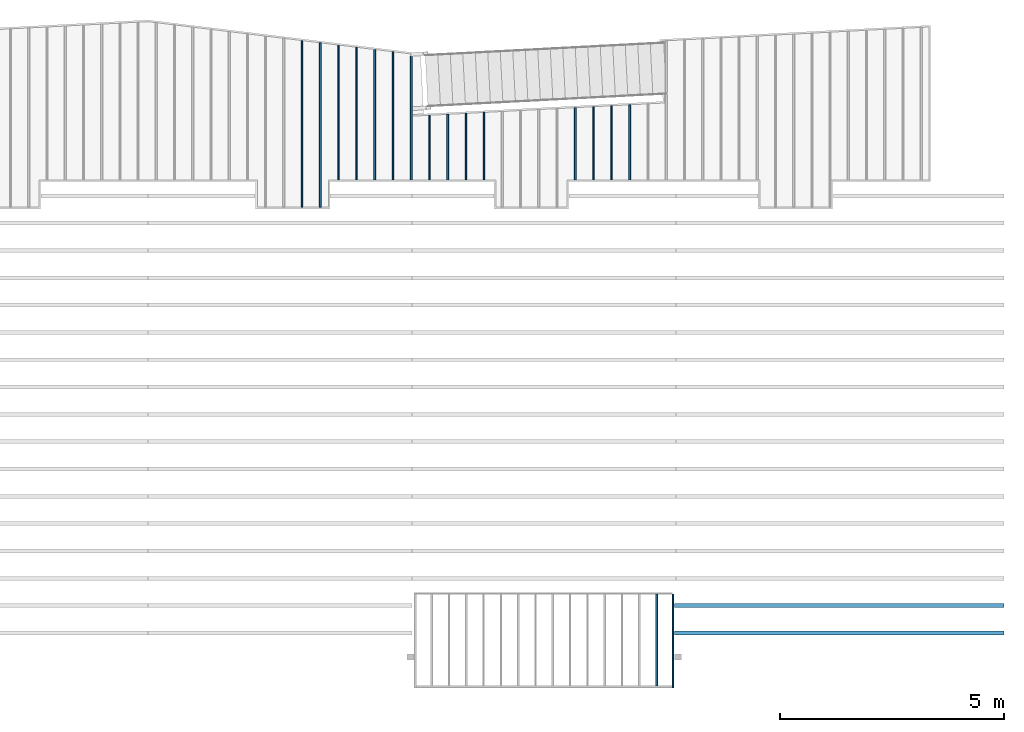
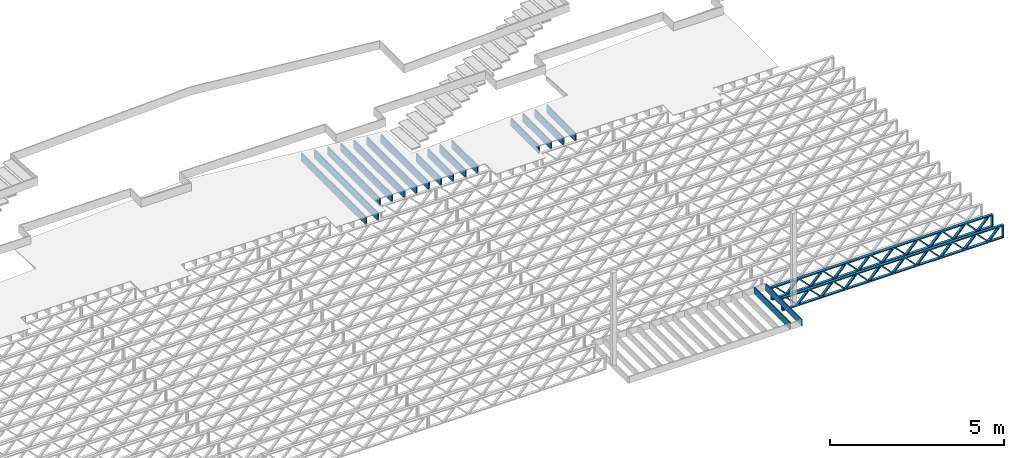
# One storey, part 10 of 23: 19 beams, 3 elements without a shape of their own.
"""IFC4 building model written with IfcOpenShell, lengths in feet."""

from ifc_helpers import new_model, entity, si_unit, converted_unit, derived_unit, direction, frame, frame_2d, origin, origin_2d_with_axis, place, context, subcontext, project, spatial, rectangle, extrude, source, transform, mapped, material, material_profile, profile_set, profile_usage, type_object, type_shapes, element, aggregate, save


model = new_model("IFC4")

# Units and contexts
model_context = context("Model", 3, precision=0.0001, world=origin(), true_north=direction((6.12303176911189e-17, 1.0)))
body_context = subcontext(model_context, "Body", "Model", "MODEL_VIEW")
ifc_project = project(units=[converted_unit("LENGTHUNIT", "FOOT", entity("IfcRatioMeasure", 0.3048), si_unit("LENGTHUNIT", "METRE"), dimensions=[1, 0, 0, 0, 0, 0, 0]), converted_unit("AREAUNIT", "SQUARE FOOT", entity("IfcRatioMeasure", 0.09290304), si_unit("AREAUNIT", "SQUARE_METRE"), dimensions=[2, 0, 0, 0, 0, 0, 0]), converted_unit("VOLUMEUNIT", "CUBIC FOOT", entity("IfcRatioMeasure", 0.028316846592), si_unit("VOLUMEUNIT", "CUBIC_METRE"), dimensions=[3, 0, 0, 0, 0, 0, 0]), converted_unit("PLANEANGLEUNIT", "DEGREE", entity("IfcRatioMeasure", 0.0174532925199433), si_unit("PLANEANGLEUNIT", "RADIAN"), dimensions=[0, 0, 0, 0, 0, 0, 0]), si_unit("MASSUNIT", "GRAM", prefix="KILO"), derived_unit("MASSDENSITYUNIT", [(si_unit("MASSUNIT", "GRAM", prefix="KILO"), 1), (si_unit("LENGTHUNIT", "METRE"), -3)]), derived_unit("MOMENTOFINERTIAUNIT", [(si_unit("LENGTHUNIT", "METRE"), 4)]), si_unit("TIMEUNIT", "SECOND"), si_unit("FREQUENCYUNIT", "HERTZ"), si_unit("THERMODYNAMICTEMPERATUREUNIT", "DEGREE_CELSIUS"), derived_unit("THERMALTRANSMITTANCEUNIT", [(si_unit("MASSUNIT", "GRAM", prefix="KILO"), 1), (si_unit("THERMODYNAMICTEMPERATUREUNIT", "KELVIN"), -1), (si_unit("TIMEUNIT", "SECOND"), -3)]), derived_unit("VOLUMETRICFLOWRATEUNIT", [(si_unit("LENGTHUNIT", "METRE"), 3), (si_unit("TIMEUNIT", "SECOND"), -1)]), si_unit("ELECTRICCURRENTUNIT", "AMPERE"), si_unit("ELECTRICVOLTAGEUNIT", "VOLT"), si_unit("POWERUNIT", "WATT"), si_unit("FORCEUNIT", "NEWTON"), si_unit("ILLUMINANCEUNIT", "LUX"), si_unit("LUMINOUSFLUXUNIT", "LUMEN"), si_unit("LUMINOUSINTENSITYUNIT", "CANDELA"), derived_unit("USERDEFINED", [(si_unit("MASSUNIT", "GRAM", prefix="KILO"), -1), (si_unit("LENGTHUNIT", "METRE"), -2), (si_unit("TIMEUNIT", "SECOND"), 3), (si_unit("LUMINOUSFLUXUNIT", "LUMEN"), 1)]), derived_unit("LINEARVELOCITYUNIT", [(si_unit("LENGTHUNIT", "METRE"), 1), (si_unit("TIMEUNIT", "SECOND"), -1)]), si_unit("PRESSUREUNIT", "PASCAL"), derived_unit("USERDEFINED", [(si_unit("LENGTHUNIT", "METRE"), -2), (si_unit("MASSUNIT", "GRAM", prefix="KILO"), 1), (si_unit("TIMEUNIT", "SECOND"), -2)]), derived_unit("LINEARFORCEUNIT", [(si_unit("MASSUNIT", "GRAM", prefix="KILO"), 1), (si_unit("LENGTHUNIT", "METRE"), 1), (si_unit("TIMEUNIT", "SECOND"), -2), (si_unit("LENGTHUNIT", "METRE"), -1)]), derived_unit("PLANARFORCEUNIT", [(si_unit("MASSUNIT", "GRAM", prefix="KILO"), 1), (si_unit("LENGTHUNIT", "METRE"), 1), (si_unit("TIMEUNIT", "SECOND"), -2), (si_unit("LENGTHUNIT", "METRE"), -2)])], contexts=[model_context])

# Site, building, storey
site_placement = place(None, origin())
site = spatial("IfcSite", under=ifc_project, at=site_placement, CompositionType="ELEMENT")
building_placement = place(site_placement, origin())
building = spatial("IfcBuilding", under=site, at=building_placement, CompositionType="ELEMENT")
storey_placement = place(building_placement, frame((0.0, 0.0, 10.8020833333333)))
storey = spatial("IfcBuildingStorey", under=building, at=storey_placement, Name="2ND FLOOR", CompositionType="ELEMENT", Elevation=10.8020833333333)

# Assembly, beam
assembly_1_placement = place(storey_placement, origin())
assembly_1 = element("IfcElementAssembly", 1, at=assembly_1_placement, inside=storey, Name="Structural Beam System:Structural Framing System", ObjectType="Structural Beam System:Structural Framing System", AssemblyPlace="NOTDEFINED", PredefinedType="BEAM_GRID")
ifc_material_1 = material(Category="Materials")
ifc_material_profile_1 = material_profile(ifc_material_1, rectangle(XDim=0.770833333333333, YDim=0.124999999999994, at=frame_2d((-5.55111512312578e-17, 0.0), x_axis=(1.0, 0.0))))
ifc_profile_set_1 = profile_set([ifc_material_profile_1])
ifc_profile_usage_1 = profile_usage(ifc_profile_set_1, cardinal=8)
beam_type_1 = type_object("IfcBeamType", PredefinedType="BEAM", material=ifc_profile_set_1)
shared_shape_1 = source(origin(), body_context, "Body", "SweptSolid", [
    extrude(rectangle(XDim=0.770833333333333, YDim=0.124999999999994, at=frame_2d((-5.55111512312578e-17, 0.0), x_axis=(1.0, 0.0))), frame((-3.35416666666737, 0.0, 0.0), z_axis=(1.0, 0.0, 0.0), x_axis=(0.0, 0.0, -1.0)), (0.0, 0.0, 1.0), 6.70833333333462),
])
type_shapes(beam_type_1, [shared_shape_1])
beam_1_placement = place(assembly_1_placement, frame((-165.83512302263, 925.341101549316, -0.645833333333471), z_axis=(0.0, 0.0, 1.0), x_axis=(0.0, 1.0, 0.0)))
beam_1 = element("IfcBeam", 2, at=beam_1_placement, type_object=beam_type_1, material=ifc_profile_usage_1, PredefinedType="BEAM", context=body_context, shape_type="MappedRepresentation", body=[
    mapped(shared_shape_1, transform((0.0, 0.0, 0.0), scale=1.0)),
])
aggregate(assembly_1, [beam_1])

# Assembly, beams
assembly_2_placement = place(storey_placement, origin())
assembly_2 = element("IfcElementAssembly", 3, at=assembly_2_placement, inside=storey, Name="Structural Beam System:Structural Framing System", ObjectType="Structural Beam System:Structural Framing System", AssemblyPlace="NOTDEFINED", PredefinedType="BEAM_GRID")
ifc_material_2 = material(Name="WOOD TRUSS", Category="Materials")
ifc_material_profile_2 = material_profile(ifc_material_2, rectangle(XDim=1.73473973950632, YDim=0.125, at=frame_2d((-1.11022302462516e-16, 8.32667268468867e-17), x_axis=(1.0, 0.0))))
ifc_material_profile_3 = material_profile(ifc_material_2, rectangle(XDim=1.73473973950633, YDim=0.125, at=frame_2d((-1.11022302462516e-16, 8.32667268468867e-17), x_axis=(1.0, 0.0))))
ifc_material_profile_4 = material_profile(ifc_material_2, rectangle(XDim=1.73473973950632, YDim=0.125, at=frame_2d((-5.55111512312578e-17, 1.38777878078145e-16), x_axis=(1.0, 0.0))))
ifc_material_profile_5 = material_profile(ifc_material_2, rectangle(XDim=1.73473973950633, YDim=0.125, at=frame_2d((-1.11022302462516e-16, 8.32667268468867e-17), x_axis=(1.0, 0.0))))
ifc_material_profile_6 = material_profile(ifc_material_2, rectangle(XDim=1.73473973950632, YDim=0.125, at=frame_2d((-1.11022302462516e-16, 8.32667268468867e-17), x_axis=(1.0, 0.0))))
ifc_material_profile_7 = material_profile(ifc_material_2, rectangle(XDim=1.73473973950633, YDim=0.125, at=frame_2d((-2.77555756156289e-16, 3.05311331771918e-16), x_axis=(1.0, 0.0))))
ifc_material_profile_8 = material_profile(ifc_material_2, rectangle(XDim=1.73473973950632, YDim=0.124999999999999, at=frame_2d((-3.88578058618805e-16, -2.4980018054066e-16), x_axis=(1.0, 0.0))))
ifc_material_profile_9 = material_profile(ifc_material_2, rectangle(XDim=1.73473973950633, YDim=0.125, at=frame_2d((2.77555756156289e-16, -3.05311331771918e-16), x_axis=(1.0, 0.0))))
ifc_material_profile_10 = material_profile(ifc_material_2, rectangle(XDim=1.73473973950632, YDim=0.124999999999999, at=frame_2d((-1.11022302462516e-16, 8.32667268468867e-17), x_axis=(1.0, 0.0))))
ifc_material_profile_11 = material_profile(ifc_material_2, rectangle(XDim=1.73473973950633, YDim=0.125, at=origin_2d_with_axis()))
ifc_material_profile_12 = material_profile(ifc_material_2, rectangle(XDim=0.124999999999982, YDim=0.291666666666668, at=origin_2d_with_axis()))
ifc_material_profile_13 = material_profile(ifc_material_2, rectangle(XDim=0.124999999999932, YDim=0.291666666666664, at=origin_2d_with_axis()))
ifc_material_profile_14 = material_profile(ifc_material_2, rectangle(XDim=1.25000000000002, YDim=0.29166666666667, at=origin_2d_with_axis()))
ifc_material_profile_15 = material_profile(ifc_material_2, rectangle(XDim=1.25000000000004, YDim=0.291666666666667, at=origin_2d_with_axis()))
ifc_profile_set_2 = profile_set([ifc_material_profile_2, ifc_material_profile_3, ifc_material_profile_4, ifc_material_profile_5, ifc_material_profile_6, ifc_material_profile_7, ifc_material_profile_8, ifc_material_profile_9, ifc_material_profile_10, ifc_material_profile_11, ifc_material_profile_12, ifc_material_profile_13, ifc_material_profile_14, ifc_material_profile_15])
ifc_profile_usage_2 = profile_usage(ifc_profile_set_2, cardinal=8)
beam_type_2 = type_object("IfcBeamType", PredefinedType="BEAM", material=ifc_profile_set_2)
shared_shape_2 = source(origin(), body_context, "Body", "SweptSolid", [
    extrude(rectangle(XDim=1.73473973950632, YDim=0.124999999999999, at=frame_2d((5.55111512312578e-16, 7.21644966006352e-16), x_axis=(1.0, 0.0))), frame((8.42202085580899, -0.145833333333334, 0.0), z_axis=(0.0, 1.0, 0.0), x_axis=(0.693383046997606, 0.0, 0.720569184836762)), (0.0, 0.0, 1.0), 0.291666666666667),
    extrude(rectangle(XDim=1.73473973950633, YDim=0.125, at=origin_2d_with_axis()), frame((7.17173498213572, -0.145833333333334, 0.0), z_axis=(0.0, 1.0, 0.0), x_axis=(0.69338304699761, 0.0, -0.720569184836758)), (0.0, 0.0, 1.0), 0.291666666666666),
    extrude(rectangle(XDim=1.73473973950632, YDim=0.124999999999999, at=frame_2d((-1.11022302462516e-16, 8.32667268468867e-17), x_axis=(1.0, 0.0))), frame((5.82306154948498, -0.145833333333334, 0.0), z_axis=(0.0, 1.0, 0.0), x_axis=(0.693383046997606, 0.0, 0.720569184836762)), (0.0, 0.0, 1.0), 0.291666666666667),
    extrude(rectangle(XDim=1.73473973950633, YDim=0.125, at=origin_2d_with_axis()), frame((4.57277567581171, -0.145833333333334, 0.0), z_axis=(0.0, 1.0, 0.0), x_axis=(0.69338304699761, 0.0, -0.720569184836758)), (0.0, 0.0, 1.0), 0.291666666666666),
    extrude(rectangle(XDim=1.73473973950632, YDim=0.125, at=frame_2d((2.22044604925031e-16, 3.88578058618805e-16), x_axis=(1.0, 0.0))), frame((3.22410224316097, -0.145833333333334, 0.0), z_axis=(0.0, 1.0, 0.0), x_axis=(0.693383046997606, 0.0, 0.720569184836762)), (0.0, 0.0, 1.0), 0.291666666666667),
    extrude(rectangle(XDim=1.73473973950633, YDim=0.125, at=frame_2d((-1.11022302462516e-16, 8.32667268468867e-17), x_axis=(1.0, 0.0))), frame((1.9738163694877, -0.145833333333334, 0.0), z_axis=(0.0, 1.0, 0.0), x_axis=(0.69338304699761, 0.0, -0.720569184836758)), (0.0, 0.0, 1.0), 0.291666666666667),
    extrude(rectangle(XDim=1.73473973950632, YDim=0.125, at=frame_2d((-5.55111512312578e-17, 1.38777878078145e-16), x_axis=(1.0, 0.0))), frame((0.625142936836964, -0.145833333333334, 0.0), z_axis=(0.0, 1.0, 0.0), x_axis=(0.693383046997606, 0.0, 0.720569184836762)), (0.0, 0.0, 1.0), 0.291666666666667),
    extrude(rectangle(XDim=1.73473973950633, YDim=0.125, at=frame_2d((-1.11022302462516e-16, 8.32667268468867e-17), x_axis=(1.0, 0.0))), frame((-0.625142936836306, -0.145833333333334, 0.0), z_axis=(0.0, 1.0, 0.0), x_axis=(0.69338304699761, 0.0, -0.720569184836758)), (0.0, 0.0, 1.0), 0.291666666666667),
    extrude(rectangle(XDim=1.73473973950632, YDim=0.125, at=frame_2d((-1.11022302462516e-16, 8.32667268468867e-17), x_axis=(1.0, 0.0))), frame((-1.97381636948704, -0.145833333333334, 0.0), z_axis=(0.0, 1.0, 0.0), x_axis=(0.693383046997606, 0.0, 0.720569184836762)), (0.0, 0.0, 1.0), 0.291666666666667),
    extrude(rectangle(XDim=1.73473973950633, YDim=0.125, at=origin_2d_with_axis()), frame((-3.22410224316031, -0.145833333333334, 0.0), z_axis=(0.0, 1.0, 0.0), x_axis=(0.69338304699761, 0.0, -0.720569184836758)), (0.0, 0.0, 1.0), 0.291666666666667),
    extrude(rectangle(XDim=1.73473973950632, YDim=0.124999999999999, at=frame_2d((-1.11022302462516e-16, 8.32667268468867e-17), x_axis=(1.0, 0.0))), frame((-4.57277567581105, -0.145833333333334, 0.0), z_axis=(0.0, 1.0, 0.0), x_axis=(0.693383046997606, 0.0, 0.720569184836762)), (0.0, 0.0, 1.0), 0.291666666666667),
    extrude(rectangle(XDim=1.73473973950633, YDim=0.125, at=origin_2d_with_axis()), frame((-5.82306154948432, -0.145833333333334, 0.0), z_axis=(0.0, 1.0, 0.0), x_axis=(0.69338304699761, 0.0, -0.720569184836758)), (0.0, 0.0, 1.0), 0.291666666666666),
    extrude(rectangle(XDim=1.73473973950632, YDim=0.124999999999999, at=frame_2d((-1.11022302462516e-16, 8.32667268468867e-17), x_axis=(1.0, 0.0))), frame((-7.17173498213506, -0.145833333333334, 0.0), z_axis=(0.0, 1.0, 0.0), x_axis=(0.693383046997606, 0.0, 0.720569184836762)), (0.0, 0.0, 1.0), 0.291666666666667),
    extrude(rectangle(XDim=1.73473973950633, YDim=0.125, at=frame_2d((-2.77555756156289e-16, 3.05311331771918e-16), x_axis=(1.0, 0.0))), frame((-8.42202085580833, -0.145833333333334, 0.0), z_axis=(0.0, 1.0, 0.0), x_axis=(0.69338304699761, 0.0, -0.720569184836758)), (0.0, 0.0, 1.0), 0.291666666666666),
    extrude(rectangle(XDim=1.73473973950632, YDim=0.125, at=frame_2d((-7.21644966006352e-16, -5.55111512312578e-16), x_axis=(1.0, 0.0))), frame((11.020980162133, -0.145833333333334, 0.0), z_axis=(0.0, 1.0, 0.0), x_axis=(0.693383046997606, 0.0, 0.720569184836762)), (0.0, 0.0, 1.0), 0.291666666666667),
    extrude(rectangle(XDim=1.73473973950633, YDim=0.125, at=origin_2d_with_axis()), frame((9.77069428845972, -0.145833333333334, 0.0), z_axis=(0.0, 1.0, 0.0), x_axis=(0.69338304699761, 0.0, -0.720569184836758)), (0.0, 0.0, 1.0), 0.291666666666666),
    extrude(rectangle(XDim=1.73473973950632, YDim=0.125, at=frame_2d((-5.55111512312578e-17, 8.32667268468867e-17), x_axis=(1.0, 0.0))), frame((-9.77069428845906, -0.145833333333334, 0.0), z_axis=(0.0, 1.0, 0.0), x_axis=(0.693383046997606, 0.0, 0.720569184836762)), (0.0, 0.0, 1.0), 0.291666666666667),
    extrude(rectangle(XDim=1.73473973950633, YDim=0.125, at=origin_2d_with_axis()), frame((-11.0209801621323, -0.145833333333334, 0.0), z_axis=(0.0, 1.0, 0.0), x_axis=(0.69338304699761, 0.0, -0.720569184836758)), (0.0, 0.0, 1.0), 0.291666666666666),
    extrude(rectangle(XDim=0.124999999999982, YDim=0.291666666666668, at=origin_2d_with_axis()), frame((-12.0625038919626, 0.0, 0.687500000000054), z_axis=(1.0, 0.0, 0.0), x_axis=(0.0, 0.0, -1.0)), (0.0, 0.0, 1.0), 24.1250077839252),
    extrude(rectangle(XDim=0.124999999999932, YDim=0.291666666666664, at=origin_2d_with_axis()), frame((-12.0625038919624, 0.0, -0.687499999999984), z_axis=(1.0, 0.0, 0.0), x_axis=(0.0, 0.0, -1.0)), (0.0, 0.0, 1.0), 24.125007783925),
    extrude(rectangle(XDim=1.25000000000002, YDim=0.29166666666667, at=origin_2d_with_axis()), frame((11.9375038919626, 0.0, 0.0), z_axis=(1.0, 0.0, 0.0), x_axis=(0.0, 0.0, -1.0)), (0.0, 0.0, 1.0), 0.12500000000002),
    extrude(rectangle(XDim=1.25000000000004, YDim=0.291666666666667, at=origin_2d_with_axis()), frame((-12.0625038919626, 0.0, 0.0), z_axis=(1.0, 0.0, 0.0), x_axis=(0.0, 0.0, -1.0)), (0.0, 0.0, 1.0), 0.125000000000023),
])
type_shapes(beam_type_2, [shared_shape_2])
beam_2_placement = place(assembly_2_placement, frame((-152.467323260299, 927.861934882651, -0.947916666657859), z_axis=(0.0, 0.0, 1.0), x_axis=(-1.0, 0.0, 0.0)))
beam_2 = element("IfcBeam", 4, at=beam_2_placement, type_object=beam_type_2, material=ifc_profile_usage_2, PredefinedType="BEAM", context=body_context, shape_type="MappedRepresentation", body=[
    mapped(shared_shape_2, transform((0.0, 0.0, 0.0), scale=1.0)),
])
ifc_profile_usage_3 = profile_usage(ifc_profile_set_2, cardinal=8)
beam_3_placement = place(assembly_2_placement, frame((-152.467323260299, 925.861934882651, -0.947916666657859), z_axis=(0.0, 0.0, 1.0), x_axis=(-1.0, 0.0, 0.0)))
beam_3 = element("IfcBeam", 5, at=beam_3_placement, type_object=beam_type_2, material=ifc_profile_usage_3, PredefinedType="BEAM", context=body_context, shape_type="MappedRepresentation", body=[
    mapped(shared_shape_2, transform((0.0, 0.0, 0.0), scale=1.0)),
])
aggregate(assembly_2, [beam_2, beam_3])

assembly_3_placement = place(storey_placement, origin())
assembly_3 = element("IfcElementAssembly", 6, at=assembly_3_placement, inside=storey, Name="Structural Beam System:Structural Framing System", ObjectType="Structural Beam System:Structural Framing System", AssemblyPlace="NOTDEFINED", PredefinedType="BEAM_GRID")
ifc_material_profile_16 = material_profile(ifc_material_1, rectangle(XDim=0.9375, YDim=0.125000000000011, at=origin_2d_with_axis()))
ifc_profile_set_3 = profile_set([ifc_material_profile_16])
ifc_profile_usage_4 = profile_usage(ifc_profile_set_3, cardinal=8)
beam_type_3 = type_object("IfcBeamType", PredefinedType="BEAM", material=ifc_profile_set_3)
shared_shape_3 = source(origin(), body_context, "Body", "SweptSolid", [
    extrude(rectangle(XDim=0.9375, YDim=0.125000000000011, at=origin_2d_with_axis()), frame((-6.09867256371109, 0.0, 0.0), z_axis=(1.0, 0.0, 0.0), x_axis=(0.0, 0.0, -1.0)), (0.0, 0.0, 1.0), 12.1973451274222),
])
type_shapes(beam_type_3, [shared_shape_3])
beam_4_placement = place(assembly_3_placement, frame((-191.800660485462, 963.127274113029, -0.729166666666744), z_axis=(0.0, 0.0, 1.0), x_axis=(0.0, 1.0, 0.0)))
beam_4 = element("IfcBeam", 7, at=beam_4_placement, type_object=beam_type_3, material=ifc_profile_usage_4, PredefinedType="BEAM", context=body_context, shape_type="MappedRepresentation", body=[
    mapped(shared_shape_3, transform((0.0, 0.0, 0.0), scale=1.0)),
])
ifc_profile_usage_5 = profile_usage(ifc_profile_set_3, cardinal=8)
beam_type_4 = type_object("IfcBeamType", PredefinedType="BEAM", material=ifc_profile_set_3)
shared_shape_4 = source(origin(), body_context, "Body", "SweptSolid", [
    extrude(rectangle(XDim=0.9375, YDim=0.125000000000011, at=origin_2d_with_axis()), frame((-6.01681618977585, 0.0, 0.0), z_axis=(1.0, 0.0, 0.0), x_axis=(0.0, 0.0, -1.0)), (0.0, 0.0, 1.0), 12.0336323795517),
])
type_shapes(beam_type_4, [shared_shape_4])
beam_5_placement = place(assembly_3_placement, frame((-190.467327152129, 963.045417739093, -0.729166666666744), z_axis=(0.0, 0.0, 1.0), x_axis=(0.0, 1.0, 0.0)))
beam_5 = element("IfcBeam", 8, at=beam_5_placement, type_object=beam_type_4, material=ifc_profile_usage_5, PredefinedType="BEAM", context=body_context, shape_type="MappedRepresentation", body=[
    mapped(shared_shape_4, transform((0.0, 0.0, 0.0), scale=1.0)),
])
ifc_profile_usage_6 = profile_usage(ifc_profile_set_3, cardinal=8)
beam_type_5 = type_object("IfcBeamType", PredefinedType="BEAM", material=ifc_profile_set_3)
shared_shape_5 = source(origin(), body_context, "Body", "SweptSolid", [
    extrude(rectangle(XDim=0.9375, YDim=0.125000000000011, at=origin_2d_with_axis()), frame((-4.93495819808015, 0.0, 0.0), z_axis=(1.0, 0.0, 0.0), x_axis=(0.0, 0.0, -1.0)), (0.0, 0.0, 1.0), 9.86991639616031),
])
type_shapes(beam_type_5, [shared_shape_5])
beam_6_placement = place(assembly_3_placement, frame((-189.133993818795, 963.963562982918, -0.729166666666744), z_axis=(0.0, 0.0, 1.0), x_axis=(0.0, 1.0, 0.0)))
beam_6 = element("IfcBeam", 9, at=beam_6_placement, type_object=beam_type_5, material=ifc_profile_usage_6, PredefinedType="BEAM", context=body_context, shape_type="MappedRepresentation", body=[
    mapped(shared_shape_5, transform((0.0, 0.0, 0.0), scale=1.0)),
])
ifc_profile_usage_7 = profile_usage(ifc_profile_set_3, cardinal=8)
beam_type_6 = type_object("IfcBeamType", PredefinedType="BEAM", material=ifc_profile_set_3)
shared_shape_6 = source(origin(), body_context, "Body", "SweptSolid", [
    extrude(rectangle(XDim=0.9375, YDim=0.125000000000011, at=origin_2d_with_axis()), frame((-4.85310198264193, 0.0, 0.0), z_axis=(1.0, 0.0, 0.0), x_axis=(0.0, 0.0, -1.0)), (0.0, 0.0, 1.0), 9.70620396528386),
])
type_shapes(beam_type_6, [shared_shape_6])
beam_7_placement = place(assembly_3_placement, frame((-187.800660485462, 963.881706450486, -0.729166666666744), z_axis=(0.0, 0.0, 1.0), x_axis=(0.0, 1.0, 0.0)))
beam_7 = element("IfcBeam", 10, at=beam_7_placement, type_object=beam_type_6, material=ifc_profile_usage_7, PredefinedType="BEAM", context=body_context, shape_type="MappedRepresentation", body=[
    mapped(shared_shape_6, transform((0.0, 0.0, 0.0), scale=1.0)),
])
ifc_profile_usage_8 = profile_usage(ifc_profile_set_3, cardinal=8)
beam_type_7 = type_object("IfcBeamType", PredefinedType="BEAM", material=ifc_profile_set_3)
shared_shape_7 = source(origin(), body_context, "Body", "SweptSolid", [
    extrude(rectangle(XDim=0.9375, YDim=0.125000000000011, at=origin_2d_with_axis()), frame((-4.77124576720365, 0.0, 0.0), z_axis=(1.0, 0.0, 0.0), x_axis=(0.0, 0.0, -1.0)), (0.0, 0.0, 1.0), 9.5424915344073),
])
type_shapes(beam_type_7, [shared_shape_7])
beam_8_placement = place(assembly_3_placement, frame((-186.467327152129, 963.799849918054, -0.729166666666744), z_axis=(0.0, 0.0, 1.0), x_axis=(0.0, 1.0, 0.0)))
beam_8 = element("IfcBeam", 11, at=beam_8_placement, type_object=beam_type_7, material=ifc_profile_usage_8, PredefinedType="BEAM", context=body_context, shape_type="MappedRepresentation", body=[
    mapped(shared_shape_7, transform((0.0, 0.0, 0.0), scale=1.0)),
])
ifc_profile_usage_9 = profile_usage(ifc_profile_set_3, cardinal=8)
beam_type_8 = type_object("IfcBeamType", PredefinedType="BEAM", material=ifc_profile_set_3)
shared_shape_8 = source(origin(), body_context, "Body", "SweptSolid", [
    extrude(rectangle(XDim=0.9375, YDim=0.125000000000011, at=origin_2d_with_axis()), frame((-4.68938955176543, 0.0, 0.0), z_axis=(1.0, 0.0, 0.0), x_axis=(0.0, 0.0, -1.0)), (0.0, 0.0, 1.0), 9.37877910353086),
])
type_shapes(beam_type_8, [shared_shape_8])
beam_9_placement = place(assembly_3_placement, frame((-185.133993818795, 963.717993385622, -0.729166666666744), z_axis=(0.0, 0.0, 1.0), x_axis=(0.0, 1.0, 0.0)))
beam_9 = element("IfcBeam", 12, at=beam_9_placement, type_object=beam_type_8, material=ifc_profile_usage_9, PredefinedType="BEAM", context=body_context, shape_type="MappedRepresentation", body=[
    mapped(shared_shape_8, transform((0.0, 0.0, 0.0), scale=1.0)),
])
ifc_profile_usage_10 = profile_usage(ifc_profile_set_3, cardinal=8)
beam_type_9 = type_object("IfcBeamType", PredefinedType="BEAM", material=ifc_profile_set_3)
shared_shape_9 = source(origin(), body_context, "Body", "SweptSolid", [
    extrude(rectangle(XDim=0.9375, YDim=0.125000000000011, at=origin_2d_with_axis()), frame((-4.63214954776987, 0.0, 0.0), z_axis=(1.0, 0.0, 0.0), x_axis=(0.0, 0.0, -1.0)), (0.0, 0.0, 1.0), 9.0453350583723),
])
type_shapes(beam_type_9, [shared_shape_9])
beam_10_placement = place(assembly_3_placement, frame((-183.800660485462, 963.660753064632, -0.729166666666744), z_axis=(0.0, 0.0, 1.0), x_axis=(0.0, 1.0, 0.0)))
beam_10 = element("IfcBeam", 13, at=beam_10_placement, type_object=beam_type_9, material=ifc_profile_usage_10, PredefinedType="BEAM", context=body_context, shape_type="MappedRepresentation", body=[
    mapped(shared_shape_9, transform((0.0, 0.0, 0.0), scale=1.0)),
])
ifc_profile_usage_11 = profile_usage(ifc_profile_set_3, cardinal=8)
beam_type_10 = type_object("IfcBeamType", PredefinedType="BEAM", material=ifc_profile_set_3)
shared_shape_10 = source(origin(), body_context, "Body", "SweptSolid", [
    extrude(rectangle(XDim=0.9375, YDim=0.125000000000011, at=origin_2d_with_axis()), frame((-2.36343114280317, 0.0, 0.0), z_axis=(1.0, 0.0, 0.0), x_axis=(0.0, 0.0, -1.0)), (0.0, 0.0, 1.0), 4.72686228560633),
])
type_shapes(beam_type_10, [shared_shape_10])
beam_11_placement = place(assembly_3_placement, frame((-182.467327152129, 961.392034342671, -0.729166666666744), z_axis=(0.0, 0.0, 1.0), x_axis=(0.0, 1.0, 0.0)))
beam_11 = element("IfcBeam", 14, at=beam_11_placement, type_object=beam_type_10, material=ifc_profile_usage_11, PredefinedType="BEAM", context=body_context, shape_type="MappedRepresentation", body=[
    mapped(shared_shape_10, transform((0.0, 0.0, 0.0), scale=1.0)),
])
ifc_profile_usage_12 = profile_usage(ifc_profile_set_3, cardinal=8)
beam_type_11 = type_object("IfcBeamType", PredefinedType="BEAM", material=ifc_profile_set_3)
shared_shape_11 = source(origin(), body_context, "Body", "SweptSolid", [
    extrude(rectangle(XDim=0.9375, YDim=0.125000000000011, at=origin_2d_with_axis()), frame((-2.39836982082215, 0.0, 0.0), z_axis=(1.0, 0.0, 0.0), x_axis=(0.0, 0.0, -1.0)), (0.0, 0.0, 1.0), 4.79673964164431),
])
type_shapes(beam_type_11, [shared_shape_11])
beam_12_placement = place(assembly_3_placement, frame((-181.133993818795, 961.426972703696, -0.729166666666744), z_axis=(0.0, 0.0, 1.0), x_axis=(0.0, 1.0, 0.0)))
beam_12 = element("IfcBeam", 15, at=beam_12_placement, type_object=beam_type_11, material=ifc_profile_usage_12, PredefinedType="BEAM", context=body_context, shape_type="MappedRepresentation", body=[
    mapped(shared_shape_11, transform((0.0, 0.0, 0.0), scale=1.0)),
])
ifc_profile_usage_13 = profile_usage(ifc_profile_set_3, cardinal=8)
beam_type_12 = type_object("IfcBeamType", PredefinedType="BEAM", material=ifc_profile_set_3)
shared_shape_12 = source(origin(), body_context, "Body", "SweptSolid", [
    extrude(rectangle(XDim=0.9375, YDim=0.125000000000011, at=origin_2d_with_axis()), frame((-2.43330849884109, 0.0, 0.0), z_axis=(1.0, 0.0, 0.0), x_axis=(0.0, 0.0, -1.0)), (0.0, 0.0, 1.0), 4.86661699768217),
])
type_shapes(beam_type_12, [shared_shape_12])
beam_13_placement = place(assembly_3_placement, frame((-179.800660485462, 961.461911064721, -0.729166666666744), z_axis=(0.0, 0.0, 1.0), x_axis=(0.0, 1.0, 0.0)))
beam_13 = element("IfcBeam", 16, at=beam_13_placement, type_object=beam_type_12, material=ifc_profile_usage_13, PredefinedType="BEAM", context=body_context, shape_type="MappedRepresentation", body=[
    mapped(shared_shape_12, transform((0.0, 0.0, 0.0), scale=1.0)),
])
ifc_profile_usage_14 = profile_usage(ifc_profile_set_3, cardinal=8)
beam_type_13 = type_object("IfcBeamType", PredefinedType="BEAM", material=ifc_profile_set_3)
shared_shape_13 = source(origin(), body_context, "Body", "SweptSolid", [
    extrude(rectangle(XDim=0.9375, YDim=0.125000000000011, at=origin_2d_with_axis()), frame((-2.46824717686007, 0.0, 0.0), z_axis=(1.0, 0.0, 0.0), x_axis=(0.0, 0.0, -1.0)), (0.0, 0.0, 1.0), 4.93649435372015),
])
type_shapes(beam_type_13, [shared_shape_13])
beam_14_placement = place(assembly_3_placement, frame((-178.467327152129, 961.496849425746, -0.729166666666744), z_axis=(0.0, 0.0, 1.0), x_axis=(0.0, 1.0, 0.0)))
beam_14 = element("IfcBeam", 17, at=beam_14_placement, type_object=beam_type_13, material=ifc_profile_usage_14, PredefinedType="BEAM", context=body_context, shape_type="MappedRepresentation", body=[
    mapped(shared_shape_13, transform((0.0, 0.0, 0.0), scale=1.0)),
])
ifc_profile_usage_15 = profile_usage(ifc_profile_set_3, cardinal=8)
beam_type_14 = type_object("IfcBeamType", PredefinedType="BEAM", material=ifc_profile_set_3)
shared_shape_14 = source(origin(), body_context, "Body", "SweptSolid", [
    extrude(rectangle(XDim=0.9375, YDim=0.125000000000011, at=origin_2d_with_axis()), frame((-2.6429404122805, 0.0, 0.0), z_axis=(1.0, 0.0, 0.0), x_axis=(0.0, 0.0, -1.0)), (0.0, 0.0, 1.0), 5.28588082456099),
])
type_shapes(beam_type_14, [shared_shape_14])
beam_15_placement = place(assembly_3_placement, frame((-171.800660485462, 961.671541385545, -0.729166666666744), z_axis=(0.0, 0.0, 1.0), x_axis=(0.0, 1.0, 0.0)))
beam_15 = element("IfcBeam", 18, at=beam_15_placement, type_object=beam_type_14, material=ifc_profile_usage_15, PredefinedType="BEAM", context=body_context, shape_type="MappedRepresentation", body=[
    mapped(shared_shape_14, transform((0.0, 0.0, 0.0), scale=1.0)),
])
ifc_profile_usage_16 = profile_usage(ifc_profile_set_3, cardinal=8)
beam_type_15 = type_object("IfcBeamType", PredefinedType="BEAM", material=ifc_profile_set_3)
shared_shape_15 = source(origin(), body_context, "Body", "SweptSolid", [
    extrude(rectangle(XDim=0.9375, YDim=0.125000000000011, at=origin_2d_with_axis()), frame((-2.67787876430128, 0.0, 0.0), z_axis=(1.0, 0.0, 0.0), x_axis=(0.0, 0.0, -1.0)), (0.0, 0.0, 1.0), 5.35575752860257),
])
type_shapes(beam_type_15, [shared_shape_15])
beam_16_placement = place(assembly_3_placement, frame((-170.467327152129, 961.706480072568, -0.729166666666744), z_axis=(0.0, 0.0, 1.0), x_axis=(0.0, 1.0, 0.0)))
beam_16 = element("IfcBeam", 19, at=beam_16_placement, type_object=beam_type_15, material=ifc_profile_usage_16, PredefinedType="BEAM", context=body_context, shape_type="MappedRepresentation", body=[
    mapped(shared_shape_15, transform((0.0, 0.0, 0.0), scale=1.0)),
])
ifc_profile_usage_17 = profile_usage(ifc_profile_set_3, cardinal=8)
beam_type_16 = type_object("IfcBeamType", PredefinedType="BEAM", material=ifc_profile_set_3)
shared_shape_16 = source(origin(), body_context, "Body", "SweptSolid", [
    extrude(rectangle(XDim=0.9375, YDim=0.125000000000011, at=origin_2d_with_axis()), frame((-2.71281711632207, 0.0, 0.0), z_axis=(1.0, 0.0, 0.0), x_axis=(0.0, 0.0, -1.0)), (0.0, 0.0, 1.0), 5.42563423264414),
])
type_shapes(beam_type_16, [shared_shape_16])
beam_17_placement = place(assembly_3_placement, frame((-169.133993818795, 961.741418759591, -0.729166666666744), z_axis=(0.0, 0.0, 1.0), x_axis=(0.0, 1.0, 0.0)))
beam_17 = element("IfcBeam", 20, at=beam_17_placement, type_object=beam_type_16, material=ifc_profile_usage_17, PredefinedType="BEAM", context=body_context, shape_type="MappedRepresentation", body=[
    mapped(shared_shape_16, transform((0.0, 0.0, 0.0), scale=1.0)),
])
ifc_profile_usage_18 = profile_usage(ifc_profile_set_3, cardinal=8)
beam_type_17 = type_object("IfcBeamType", PredefinedType="BEAM", material=ifc_profile_set_3)
shared_shape_17 = source(origin(), body_context, "Body", "SweptSolid", [
    extrude(rectangle(XDim=0.9375, YDim=0.125000000000011, at=origin_2d_with_axis()), frame((-2.7477554683428, 0.0, 0.0), z_axis=(1.0, 0.0, 0.0), x_axis=(0.0, 0.0, -1.0)), (0.0, 0.0, 1.0), 5.49551093668561),
])
type_shapes(beam_type_17, [shared_shape_17])
beam_18_placement = place(assembly_3_placement, frame((-167.800660485462, 961.776357446614, -0.729166666666744), z_axis=(0.0, 0.0, 1.0), x_axis=(0.0, 1.0, 0.0)))
beam_18 = element("IfcBeam", 21, at=beam_18_placement, type_object=beam_type_17, material=ifc_profile_usage_18, PredefinedType="BEAM", context=body_context, shape_type="MappedRepresentation", body=[
    mapped(shared_shape_17, transform((0.0, 0.0, 0.0), scale=1.0)),
])
aggregate(assembly_3, [beam_4, beam_5, beam_6, beam_7, beam_8, beam_9, beam_10, beam_11, beam_12, beam_13, beam_14, beam_15, beam_16, beam_17, beam_18])

# Beam
ifc_profile_usage_19 = profile_usage(ifc_profile_set_1, cardinal=8)
beam_type_18 = type_object("IfcBeamType", PredefinedType="BEAM", material=ifc_profile_set_1)
shared_shape_18 = source(origin(), body_context, "Body", "SweptSolid", [
    extrude(rectangle(XDim=0.770833333333333, YDim=0.124999999999994, at=frame_2d((-5.55111512312578e-17, 0.0), x_axis=(1.0, 0.0))), frame((-3.47916666666737, 0.0, 0.0), z_axis=(1.0, 0.0, 0.0), x_axis=(0.0, 0.0, -1.0)), (0.0, 0.0, 1.0), 6.83333333333485),
])
type_shapes(beam_type_18, [shared_shape_18])
beam_19_placement = place(storey_placement, frame((-164.633993818862, 925.341101549316, -0.645833333332796), z_axis=(0.0, 0.0, 1.0), x_axis=(0.0, 1.0, 0.0)))
element("IfcBeam", 22, at=beam_19_placement, inside=storey, type_object=beam_type_18, material=ifc_profile_usage_19, PredefinedType="BEAM", context=body_context, shape_type="MappedRepresentation", body=[
    mapped(shared_shape_18, transform((0.0, 0.0, 0.0), scale=1.0)),
])

save(model, "model.ifc")
